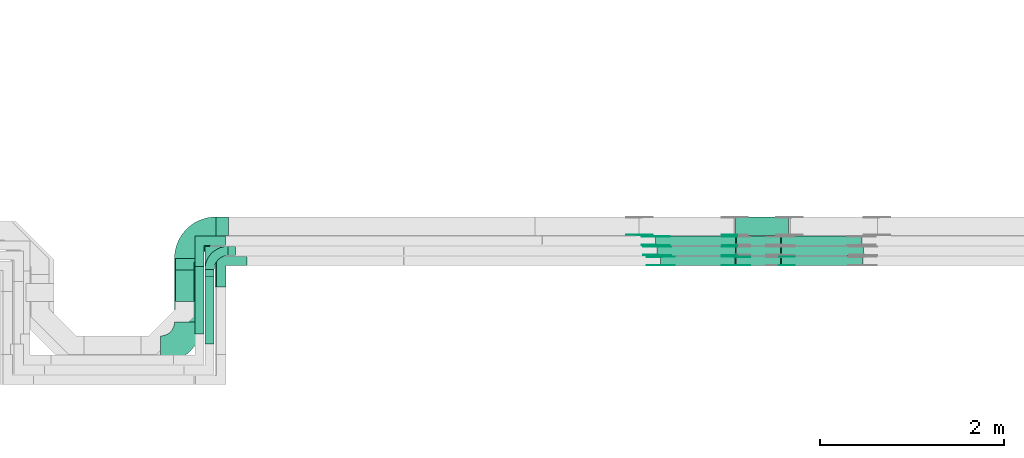
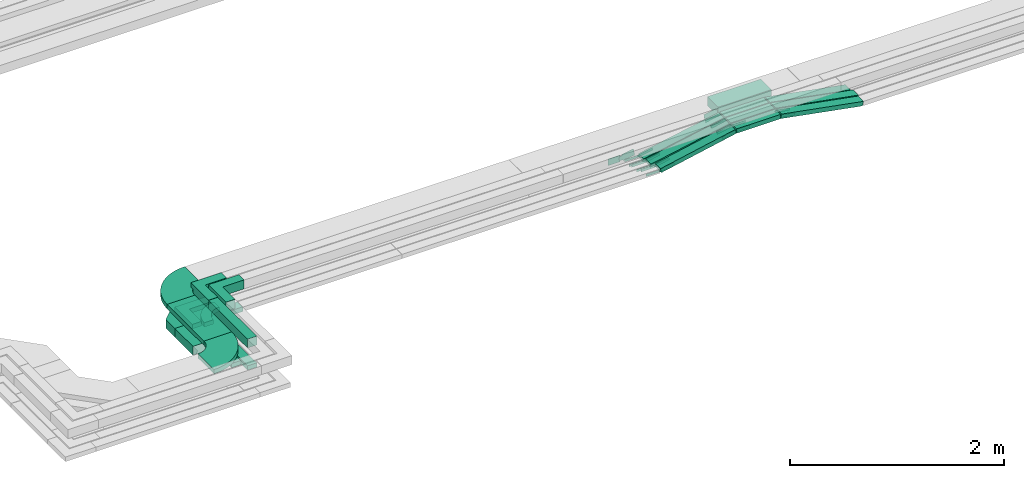
# One storey, part 20 of 32: 33 flow fittings, 15 flow segments.
"""IFC2X3 building model written with IfcOpenShell, lengths in millimetres."""

from ifc_helpers import new_model, entity, si_unit, converted_unit, derived_unit, direction, frame, frame_2d, origin, origin_2d_with_axis, place, context, subcontext, project, spatial, polyline, circle_curve, parameter, trimmed, segment, composite_curve, rectangle, outline, extrude, source, transform, mapped, material, type_object, type_shapes, element, save


model = new_model("IFC2X3")

# Units and contexts
model_context = context("Model", 3, precision=0.01, world=origin(), true_north=direction((6.12303176911189e-17, 1.0)))
body_context = subcontext(model_context, "Body", "Model", "MODEL_VIEW")
ifc_project = project(units=[si_unit("LENGTHUNIT", "METRE", prefix="MILLI"), si_unit("AREAUNIT", "SQUARE_METRE"), si_unit("VOLUMEUNIT", "CUBIC_METRE"), converted_unit("PLANEANGLEUNIT", "DEGREE", entity("IfcRatioMeasure", 0.0174532925199433), si_unit("PLANEANGLEUNIT", "RADIAN"), dimensions=[0, 0, 0, 0, 0, 0, 0]), si_unit("MASSUNIT", "GRAM", prefix="KILO"), derived_unit("MASSDENSITYUNIT", [(si_unit("MASSUNIT", "GRAM", prefix="KILO"), 1), (si_unit("LENGTHUNIT", "METRE"), -3)]), derived_unit("MOMENTOFINERTIAUNIT", [(si_unit("LENGTHUNIT", "METRE"), 4)]), si_unit("TIMEUNIT", "SECOND"), si_unit("FREQUENCYUNIT", "HERTZ"), si_unit("THERMODYNAMICTEMPERATUREUNIT", "DEGREE_CELSIUS"), derived_unit("THERMALTRANSMITTANCEUNIT", [(si_unit("MASSUNIT", "GRAM", prefix="KILO"), 1), (si_unit("THERMODYNAMICTEMPERATUREUNIT", "KELVIN"), -1), (si_unit("TIMEUNIT", "SECOND"), -3)]), derived_unit("VOLUMETRICFLOWRATEUNIT", [(si_unit("LENGTHUNIT", "METRE"), 3), (si_unit("TIMEUNIT", "SECOND"), -1)]), derived_unit("MASSFLOWRATEUNIT", [(si_unit("MASSUNIT", "GRAM", prefix="KILO"), 1), (si_unit("TIMEUNIT", "SECOND"), -1)]), derived_unit("ROTATIONALFREQUENCYUNIT", [(si_unit("TIMEUNIT", "SECOND"), -1)]), si_unit("ELECTRICCURRENTUNIT", "AMPERE"), si_unit("ELECTRICVOLTAGEUNIT", "VOLT"), si_unit("POWERUNIT", "WATT"), si_unit("FORCEUNIT", "NEWTON", prefix="KILO"), si_unit("ILLUMINANCEUNIT", "LUX"), si_unit("LUMINOUSFLUXUNIT", "LUMEN"), si_unit("LUMINOUSINTENSITYUNIT", "CANDELA"), derived_unit("USERDEFINED", [(si_unit("MASSUNIT", "GRAM", prefix="KILO"), -1), (si_unit("LENGTHUNIT", "METRE"), -2), (si_unit("TIMEUNIT", "SECOND"), 3), (si_unit("LUMINOUSFLUXUNIT", "LUMEN"), 1)]), derived_unit("LINEARVELOCITYUNIT", [(si_unit("LENGTHUNIT", "METRE"), 1), (si_unit("TIMEUNIT", "SECOND"), -1)]), si_unit("PRESSUREUNIT", "PASCAL"), derived_unit("USERDEFINED", [(si_unit("LENGTHUNIT", "METRE"), -2), (si_unit("MASSUNIT", "GRAM", prefix="KILO"), 1), (si_unit("TIMEUNIT", "SECOND"), -2)]), derived_unit("LINEARFORCEUNIT", [(si_unit("MASSUNIT", "GRAM", prefix="KILO"), 1), (si_unit("LENGTHUNIT", "METRE"), 1), (si_unit("TIMEUNIT", "SECOND"), -2), (si_unit("LENGTHUNIT", "METRE"), -1)]), derived_unit("PLANARFORCEUNIT", [(si_unit("MASSUNIT", "GRAM", prefix="KILO"), 1), (si_unit("LENGTHUNIT", "METRE"), 1), (si_unit("TIMEUNIT", "SECOND"), -2), (si_unit("LENGTHUNIT", "METRE"), -2)])], contexts=[model_context])

# Site, building, storey
site_placement = place(None, origin())
site = spatial("IfcSite", under=ifc_project, at=site_placement, CompositionType="ELEMENT")
building_placement = place(site_placement, origin())
building = spatial("IfcBuilding", under=site, at=building_placement, CompositionType="ELEMENT")
storey_placement = place(building_placement, frame((0.0, 0.0, 8100.0)))
storey = spatial("IfcBuildingStorey", under=building, at=storey_placement, CompositionType="ELEMENT", Elevation=8100.0)

# Flow segments
cable_carrier_segment_type = type_object("IfcCableCarrierSegmentType", PredefinedType="CABLETRAYSEGMENT")
flow_segment_1_placement = place(storey_placement, frame((44557.72, 9083.69, 2800.02)))
element("IfcFlowSegment", 1, at=flow_segment_1_placement, inside=storey, type_object=cable_carrier_segment_type, context=body_context, shape_type="SweptSolid", body=[
    extrude(rectangle(XDim=690.309773162948, YDim=300.000000000001, at=origin_2d_with_axis()), frame((150.0, 345.15, 0.0), z_axis=(0.0, 0.0, 1.0), x_axis=(0.0, -1.0, 0.0)), (0.0, 0.0, 1.0), 50.0000000000016),
])
flow_segment_2_placement = place(storey_placement, frame((44889.39, 8842.69, 2800.01)))
element("IfcFlowSegment", 2, at=flow_segment_2_placement, inside=storey, type_object=cable_carrier_segment_type, context=body_context, shape_type="SweptSolid", body=[
    extrude(rectangle(XDim=732.309773162997, YDim=99.9999999999946, at=origin_2d_with_axis()), frame((50.0, 366.15, 0.0), z_axis=(0.0, 0.0, 1.0), x_axis=(0.0, -1.0, 0.0)), (0.0, 0.0, 1.0), 99.9999999999968),
])
flow_segment_3_placement = place(storey_placement, frame((44569.39, 9308.69, 2547.39)))
element("IfcFlowSegment", 3, at=flow_segment_3_placement, inside=storey, type_object=cable_carrier_segment_type, context=body_context, shape_type="SweptSolid", body=[
    extrude(rectangle(XDim=340.309773162912, YDim=200.000000000007, at=origin_2d_with_axis()), frame((100.0, 170.15, 0.0), z_axis=(0.0, 0.0, 1.0), x_axis=(0.0, 1.0, 0.0)), (0.0, 0.0, 1.0), 99.9999999999989),
])
flow_segment_4_placement = place(storey_placement, frame((44779.39, 8952.69, 2544.93)))
element("IfcFlowSegment", 4, at=flow_segment_4_placement, inside=storey, type_object=cable_carrier_segment_type, context=body_context, shape_type="SweptSolid", body=[
    extrude(rectangle(XDim=732.309773162961, YDim=99.9999999999946, at=origin_2d_with_axis()), frame((50.0, 366.15, 0.0), z_axis=(0.0, 0.0, 1.0), x_axis=(0.0, 1.0, 0.0)), (0.0, 0.0, 1.0), 50.0000000000016),
])
flow_segment_5_placement = place(storey_placement, frame((44889.39, 8842.69, 2546.32)))
element("IfcFlowSegment", 5, at=flow_segment_5_placement, inside=storey, type_object=cable_carrier_segment_type, context=body_context, shape_type="SweptSolid", body=[
    extrude(rectangle(XDim=811.309773162958, YDim=99.9999999999946, at=origin_2d_with_axis()), frame((50.0, 405.65, 0.0), z_axis=(0.0, 0.0, 1.0), x_axis=(0.0, 1.0, 0.0)), (0.0, 0.0, 1.0), 50.0000000000016),
])
flow_segment_6_placement = place(storey_placement, frame((50660.64, 9695.0, 2713.3)))
element("IfcFlowSegment", 6, at=flow_segment_6_placement, inside=storey, type_object=cable_carrier_segment_type, context=body_context, shape_type="SweptSolid", body=[
    extrude(rectangle(XDim=477.273522129145, YDim=100.000000000001, at=origin_2d_with_axis()), frame((238.64, 50.0, 0.0)), (0.0, 0.0, 1.0), 50.0000000000017),
])
flow_segment_7_placement = place(storey_placement, frame((50650.96, 10025.0, 2713.61)))
element("IfcFlowSegment", 7, at=flow_segment_7_placement, inside=storey, type_object=cable_carrier_segment_type, context=body_context, shape_type="SweptSolid", body=[
    extrude(rectangle(XDim=577.431980396776, YDim=199.999999999998, at=origin_2d_with_axis()), frame((288.72, 100.0, 0.0)), (0.0, 0.0, 1.0), 99.9999999999989),
])
flow_segment_8_placement = place(storey_placement, frame((50662.44, 9915.0, 2713.31)))
element("IfcFlowSegment", 8, at=flow_segment_8_placement, inside=storey, type_object=cable_carrier_segment_type, context=body_context, shape_type="SweptSolid", body=[
    extrude(rectangle(XDim=475.291800517506, YDim=99.9999999999989, at=origin_2d_with_axis()), frame((237.65, 50.0, 0.0)), (0.0, 0.0, 1.0), 50.0000000000016),
])
flow_segment_9_placement = place(storey_placement, frame((50661.26, 9805.0, 2713.54)))
element("IfcFlowSegment", 9, at=flow_segment_9_placement, inside=storey, type_object=cable_carrier_segment_type, context=body_context, shape_type="SweptSolid", body=[
    extrude(rectangle(XDim=476.37052042903, YDim=99.9999999999989, at=origin_2d_with_axis()), frame((238.19, 50.0, 0.0), z_axis=(0.0, 0.0, 1.0), x_axis=(-1.0, 0.0, 0.0)), (0.0, 0.0, 1.0), 50.0000000000016),
])
flow_segment_10_placement = place(storey_placement, frame((49839.4, 9695.0, 2547.96)))
element("IfcFlowSegment", 10, at=flow_segment_10_placement, inside=storey, type_object=cable_carrier_segment_type, context=body_context, shape_type="SweptSolid", body=[
    extrude(rectangle(XDim=50.0000000000023, YDim=100.000000000001, at=origin_2d_with_axis()), frame((5.0, 50.0, 24.5), z_axis=(0.979786827050049, 0.0, 0.200044428913172), x_axis=(-0.200044428890075, 1.51960900459464e-05, 0.979786826936922)), (0.0, 0.0, 1.0), 825.136376037674),
])
flow_segment_11_placement = place(storey_placement, frame((51140.63, 9695.0, 2549.42)))
element("IfcFlowSegment", 11, at=flow_segment_11_placement, inside=storey, type_object=cable_carrier_segment_type, context=body_context, shape_type="SweptSolid", body=[
    extrude(rectangle(XDim=50.0000000000012, YDim=100.000000000001, at=origin_2d_with_axis()), frame((4.56, 50.0, 188.22), z_axis=(0.983194962125325, 0.0, -0.182558665780022), x_axis=(0.182558665780022, 0.0, 0.983194962125325)), (0.0, 0.0, 1.0), 896.373011194787),
])
flow_segment_12_placement = place(storey_placement, frame((49799.87, 9805.0, 2547.51)))
element("IfcFlowSegment", 12, at=flow_segment_12_placement, inside=storey, type_object=cable_carrier_segment_type, context=body_context, shape_type="SweptSolid", body=[
    extrude(rectangle(XDim=49.9999999999987, YDim=99.9999999999989, at=origin_2d_with_axis()), frame((4.79, 50.0, 24.54), z_axis=(0.981470478195865, 0.0, 0.191613414013684), x_axis=(-0.191613414013684, 0.0, 0.981470478195865)), (0.0, 0.0, 1.0), 865.091688195415),
])
flow_segment_13_placement = place(storey_placement, frame((51140.33, 9805.0, 2551.09)))
element("IfcFlowSegment", 13, at=flow_segment_13_placement, inside=storey, type_object=cable_carrier_segment_type, context=body_context, shape_type="SweptSolid", body=[
    extrude(rectangle(XDim=50.0000000000008, YDim=99.9999999999989, at=frame_2d((0.0, 0.0), x_axis=(0.0, 1.0))), frame((4.47, 50.0, 186.81), z_axis=(0.983855320382255, 0.0, -0.178965663062864), x_axis=(0.0, 1.0, 0.0)), (0.0, 0.0, 1.0), 906.383158684558),
])
flow_segment_14_placement = place(storey_placement, frame((49784.86, 9915.0, 2546.09)))
element("IfcFlowSegment", 14, at=flow_segment_14_placement, inside=storey, type_object=cable_carrier_segment_type, context=body_context, shape_type="SweptSolid", body=[
    extrude(rectangle(XDim=50.0000000000003, YDim=99.9999999999989, at=origin_2d_with_axis()), frame((4.74, 50.0, 24.55), z_axis=(0.981892404551273, 0.0, 0.189439451763671), x_axis=(-0.189439451763671, 0.0, 0.981892404551273)), (0.0, 0.0, 1.0), 881.321250243893),
])
flow_segment_15_placement = place(storey_placement, frame((51140.45, 9915.0, 2550.97)))
element("IfcFlowSegment", 15, at=flow_segment_15_placement, inside=storey, type_object=cable_carrier_segment_type, context=body_context, shape_type="SweptSolid", body=[
    extrude(rectangle(XDim=50.0000000000006, YDim=99.9999999999989, at=frame_2d((0.0, 0.0), x_axis=(0.0, 1.0))), frame((4.57, 50.0, 186.67), z_axis=(0.983116338122434, 0.0, -0.182981599393862), x_axis=(0.0, 1.0, 0.0)), (0.0, 0.0, 1.0), 885.843681158498),
])

# Flow fittings
ifc_material_1 = material()
cable_carrier_fitting_type_1 = type_object("IfcCableCarrierFittingType", Name="470_DKC_G5_Sheet horizontal bend:-", PredefinedType="NOTDEFINED", material=ifc_material_1)
shared_shape_1 = source(origin(), body_context, "Body", "SweptSolid", [
    extrude(outline(polyline([(-269.5, -306.5), (-102.08, -306.5), (306.5, 102.08), (306.5, 269.5), (106.5, 269.5), (106.5, 184.92), (-184.92, -106.5), (-269.5, -106.5), (-269.5, -306.5)])), frame((-206.5, 206.5, -50.0)), (0.0, 0.0, 1.0), 100.0),
])
type_shapes(cable_carrier_fitting_type_1, [shared_shape_1])
flow_fitting_1_placement = place(storey_placement, frame((44669.39, 10125.0, 2597.39), z_axis=(0.0, 0.0, 1.0), x_axis=(-1.0, 0.0, 0.0)))
element("IfcFlowFitting", 16, at=flow_fitting_1_placement, inside=storey, type_object=cable_carrier_fitting_type_1, material=ifc_material_1, Name="470_DKC_G5_Sheet horizontal bend:-", ObjectType="470_DKC_G5_Sheet horizontal bend:-", context=body_context, shape_type="MappedRepresentation", body=[
    mapped(shared_shape_1, transform((0.0, 0.0, 0.0), scale=1.0)),
])
cable_carrier_fitting_type_2 = type_object("IfcCableCarrierFittingType", Name="470_DKC_F5_Mesh horizontal angle:At right angles", PredefinedType="NOTDEFINED", material=ifc_material_1)
shared_shape_2 = source(origin(), body_context, "Body", "SweptSolid", [
    extrude(outline(polyline([(-143.33, -143.33), (186.67, -143.33), (186.67, -43.33), (-43.33, -43.33), (-43.33, 186.67), (-143.33, 186.67), (-143.33, -143.33)])), frame((-93.33, 93.33, -25.0), z_axis=(0.0, 0.0, 1.0), x_axis=(0.0, 1.0, 0.0)), (0.0, 0.0, 1.0), 51.9999999999999),
])
type_shapes(cable_carrier_fitting_type_2, [shared_shape_2])
for number, where, z_axis, x_axis, name in (
    (17, (44829.39, 9965.0, 2569.93), (0.0, 0.0, 1.0), (-1.0, 0.0, 0.0), "470_DKC_F5_Mesh horizontal angle:At right angles"),
    (18, (45049.9, 9745.0, 2571.67), (0.0, 0.0, 1.0), (-1.0, 0.0, 0.0), "470_DKC_F5_Mesh horizontal angle:At right angles"),
):
    element("IfcFlowFitting", number, at=place(storey_placement, frame(where, z_axis=z_axis, x_axis=x_axis)), inside=storey, type_object=cable_carrier_fitting_type_2, material=ifc_material_1, Name=name, ObjectType="470_DKC_F5_Mesh horizontal angle:At right angles", context=body_context, shape_type="MappedRepresentation", body=[
        mapped(shared_shape_2, transform((0.0, 0.0, 0.0), scale=1.0)),
    ])
cable_carrier_fitting_type_3 = type_object("IfcCableCarrierFittingType", Name="470_DKC_F5_Mesh horizontal angle:At right angles", PredefinedType="NOTDEFINED", material=ifc_material_1)
shared_shape_3 = source(origin(), body_context, "Body", "SweptSolid", [
    extrude(outline(polyline([(-143.33, -143.33), (186.67, -143.33), (186.67, -43.33), (-43.33, -43.33), (-43.33, 186.67), (-143.33, 186.67), (-143.33, -143.33)])), frame((-93.33, 93.33, -50.0), z_axis=(0.0, 0.0, 1.0), x_axis=(0.0, 1.0, 0.0)), (0.0, 0.0, 1.0), 102.0),
])
type_shapes(cable_carrier_fitting_type_3, [shared_shape_3])
for number, where, z_axis, x_axis, name in (
    (19, (44939.39, 9855.0, 2850.01), (2.17578588737003e-05, 0.0, 1.0), (-1.0, 0.0, 2.17578588737003e-05), "470_DKC_F5_Mesh horizontal angle:At right angles"),
    (20, (45064.9, 9745.0, 2849.28), (4.69987070140133e-07, 0.0, 1.0), (-1.0, 0.0, 4.69987070140133e-07), "470_DKC_F5_Mesh horizontal angle:At right angles"),
):
    element("IfcFlowFitting", number, at=place(storey_placement, frame(where, z_axis=z_axis, x_axis=x_axis)), inside=storey, type_object=cable_carrier_fitting_type_3, material=ifc_material_1, Name=name, ObjectType="470_DKC_F5_Mesh horizontal angle:At right angles", context=body_context, shape_type="MappedRepresentation", body=[
        mapped(shared_shape_3, transform((0.0, 0.0, 0.0), scale=1.0)),
    ])
cable_carrier_fitting_type_4 = type_object("IfcCableCarrierFittingType", Name="470_DKC_S5_Variable Angle Elbow 0-45:-", PredefinedType="NOTDEFINED", material=ifc_material_1)
shared_shape_4 = source(origin(), body_context, "Body", "SweptSolid", [
    extrude(outline(composite_curve([segment(polyline([(-150.75, -300.25), (-149.75, -300.25)]), True, "CONTINUOUS"), segment(trimmed(circle_curve(frame_2d((-149.75, 149.75), x_axis=(0.0, -1.0)), 450.0), [parameter(0.0)], [parameter(90.0000000000001)], True, "PARAMETER"), True, "CONTINUOUS"), segment(polyline([(300.25, 149.75), (300.25, 150.75)]), True, "CONTINUOUS"), segment(polyline([(300.25, 150.75), (0.25, 150.75)]), True, "CONTINUOUS"), segment(polyline([(0.25, 150.75), (0.25, 149.75)]), True, "CONTINUOUS"), segment(trimmed(circle_curve(frame_2d((-149.75, 149.75), x_axis=(0.0, -1.0)), 150.0), [parameter(0.0)], [parameter(90.0000000000001)], True, "PARAMETER"), False, "CONTINUOUS"), segment(polyline([(-149.75, -0.25), (-150.75, -0.25)]), True, "CONTINUOUS"), segment(polyline([(-150.75, -0.25), (-150.75, -300.25)]), True, "CONTINUOUS")], self_intersect=False)), frame((-150.25, 150.25, -25.0)), (0.0, 0.0, 1.0), 49.9999999999974),
])
type_shapes(cable_carrier_fitting_type_4, [shared_shape_4])
flow_fitting_2_placement = place(storey_placement, frame((44707.72, 8782.69, 2825.02)))
element("IfcFlowFitting", 21, at=flow_fitting_2_placement, inside=storey, type_object=cable_carrier_fitting_type_4, material=ifc_material_1, Name="470_DKC_S5_Variable Angle Elbow 0-45:-", ObjectType="470_DKC_S5_Variable Angle Elbow 0-45:-", context=body_context, shape_type="MappedRepresentation", body=[
    mapped(shared_shape_4, transform((0.0, 0.0, 0.0), scale=1.0)),
])
flow_fitting_3_placement = place(storey_placement, frame((44707.72, 10075.0, 2825.02), z_axis=(0.00105535618082575, 0.0, 0.999999443111511), x_axis=(-0.999999443111511, 0.0, 0.00105535618082575)))
element("IfcFlowFitting", 22, at=flow_fitting_3_placement, inside=storey, type_object=cable_carrier_fitting_type_4, material=ifc_material_1, Name="470_DKC_S5_Variable Angle Elbow 0-45:-", ObjectType="470_DKC_S5_Variable Angle Elbow 0-45:-", context=body_context, shape_type="MappedRepresentation", body=[
    mapped(shared_shape_4, transform((0.0, 0.0, 0.0), scale=1.0)),
])
cable_carrier_fitting_type_5 = type_object("IfcCableCarrierFittingType", Name="470_DKC_S5_Variable Angle Elbow 0-45:-", PredefinedType="NOTDEFINED", material=ifc_material_1)
shared_shape_5 = source(origin(), body_context, "Body", "SweptSolid", [
    extrude(outline(composite_curve([segment(polyline([(-100.75, -150.25), (-99.75, -150.25)]), True, "CONTINUOUS"), segment(trimmed(circle_curve(frame_2d((-99.75, 99.75), x_axis=(0.0, -1.0)), 250.0), [parameter(0.0)], [parameter(90.0000000000001)], True, "PARAMETER"), True, "CONTINUOUS"), segment(polyline([(150.25, 99.75), (150.25, 100.75)]), True, "CONTINUOUS"), segment(polyline([(150.25, 100.75), (50.25, 100.75)]), True, "CONTINUOUS"), segment(polyline([(50.25, 100.75), (50.25, 99.75)]), True, "CONTINUOUS"), segment(trimmed(circle_curve(frame_2d((-99.75, 99.75), x_axis=(0.0, -1.0)), 150.0), [parameter(0.0)], [parameter(90.0000000000001)], True, "PARAMETER"), False, "CONTINUOUS"), segment(polyline([(-99.75, -50.25), (-100.75, -50.25)]), True, "CONTINUOUS"), segment(polyline([(-100.75, -50.25), (-100.75, -150.25)]), True, "CONTINUOUS")], self_intersect=False)), frame((-100.25, 100.25, -25.0)), (0.0, 0.0, 1.0), 49.9999999999997),
])
type_shapes(cable_carrier_fitting_type_5, [shared_shape_5])
flow_fitting_4_placement = place(storey_placement, frame((44939.39, 9855.0, 2571.32), z_axis=(0.0, 0.0, 1.0), x_axis=(-1.0, 0.0, 0.0)))
element("IfcFlowFitting", 23, at=flow_fitting_4_placement, inside=storey, type_object=cable_carrier_fitting_type_5, material=ifc_material_1, Name="470_DKC_S5_Variable Angle Elbow 0-45:-", ObjectType="470_DKC_S5_Variable Angle Elbow 0-45:-", context=body_context, shape_type="MappedRepresentation", body=[
    mapped(shared_shape_5, transform((0.0, 0.0, 0.0), scale=1.0)),
])
ifc_material_2 = material(Name="G")
cable_carrier_fitting_type_6 = type_object("IfcCableCarrierFittingType", PredefinedType="NOTDEFINED", material=ifc_material_2)
shared_shape_6 = source(origin(), body_context, "Body", "SweptSolid", [
    extrude(outline(composite_curve([segment(trimmed(circle_curve(frame_2d((-44.59, 0.0), x_axis=(1.0, 0.0)), 12.5), [parameter(90.0000000000007)], [parameter(270.0)], True, "PARAMETER"), True, "CONTINUOUS"), segment(polyline([(-44.59, -12.5), (-33.09, -12.5)]), True, "CONTINUOUS"), segment(polyline([(-33.09, -12.5), (-31.23, -14.5)]), True, "CONTINUOUS"), segment(polyline([(-31.23, -14.5), (108.91, -14.5)]), True, "CONTINUOUS"), segment(polyline([(108.91, -14.5), (108.91, 14.5)]), True, "CONTINUOUS"), segment(polyline([(108.91, 14.5), (-31.23, 14.5)]), True, "CONTINUOUS"), segment(polyline([(-31.23, 14.5), (-33.09, 12.5)]), True, "CONTINUOUS"), segment(polyline([(-33.09, 12.5), (-44.59, 12.5)]), True, "CONTINUOUS")], self_intersect=False)), frame((44.59, 0.0, 0.0), z_axis=(0.0, 0.0, -1.0), x_axis=(1.0, 0.0, 0.0)), (0.0, 0.0, -1.0), 2.0),
])
type_shapes(cable_carrier_fitting_type_6, [shared_shape_6])
flow_fitting_5_placement = place(storey_placement, frame((49840.55, 9699.54, 2571.67), z_axis=(0.0, -1.0, 0.0), x_axis=(0.979786827050029, 0.0, 0.200044428913269)))
element("IfcFlowFitting", 24, at=flow_fitting_5_placement, inside=storey, type_object=cable_carrier_fitting_type_6, material=ifc_material_2, context=body_context, shape_type="MappedRepresentation", body=[
    mapped(shared_shape_6, transform((0.0, 0.0, 0.0), scale=1.0)),
])
cable_carrier_fitting_type_7 = type_object("IfcCableCarrierFittingType", PredefinedType="NOTDEFINED", material=ifc_material_2)
type_shapes(cable_carrier_fitting_type_7, [shared_shape_6])
flow_fitting_6_placement = place(storey_placement, frame((49840.55, 9788.46, 2571.67), z_axis=(0.0, 1.0, 0.0), x_axis=(-1.0, 0.0, 0.0)))
element("IfcFlowFitting", 25, at=flow_fitting_6_placement, inside=storey, type_object=cable_carrier_fitting_type_7, material=ifc_material_2, context=body_context, shape_type="MappedRepresentation", body=[
    mapped(shared_shape_6, transform((0.0, 0.0, 0.0), scale=1.0)),
])
flow_fitting_7_placement = place(storey_placement, frame((50656.71, 9699.54, 2738.31), z_axis=(-3.03989314942444e-06, -1.0, 1.48889288550001e-05), x_axis=(-0.979786827054556, 0.0, -0.200044428891096)))
element("IfcFlowFitting", 26, at=flow_fitting_7_placement, inside=storey, type_object=cable_carrier_fitting_type_6, material=ifc_material_2, context=body_context, shape_type="MappedRepresentation", body=[
    mapped(shared_shape_6, transform((0.0, 0.0, 0.0), scale=1.0)),
])
flow_fitting_8_placement = place(storey_placement, frame((50656.71, 9788.46, 2738.31), z_axis=(3.03989316299203e-06, 1.0, -1.48889288550001e-05), x_axis=(1.0, -3.03989316332888e-06, 0.0)))
element("IfcFlowFitting", 27, at=flow_fitting_8_placement, inside=storey, type_object=cable_carrier_fitting_type_7, material=ifc_material_2, context=body_context, shape_type="MappedRepresentation", body=[
    mapped(shared_shape_6, transform((0.0, 0.0, 0.0), scale=1.0)),
])
for number, where, z_axis, x_axis in (
    (28, (51141.58, 9790.46, 2738.31), (3.03989318177189e-06, 1.0, 1.63717654735008e-05), (0.983194962125356, 0.0, -0.182558665779853)),
    (29, (50657.45, 9809.54, 2738.54), (0.0, -1.0, 0.0), (-0.981470478195842, 0.0, -0.191613414013801)),
    (30, (49800.92, 9809.54, 2571.32), (0.0, -1.0, 0.0), (0.981470478195842, 0.0, 0.191613414013801)),
):
    element("IfcFlowFitting", number, at=place(storey_placement, frame(where, z_axis=z_axis, x_axis=x_axis)), inside=storey, type_object=cable_carrier_fitting_type_6, material=ifc_material_2, context=body_context, shape_type="MappedRepresentation", body=[
        mapped(shared_shape_6, transform((0.0, 0.0, 0.0), scale=1.0)),
    ])
flow_fitting_9_placement = place(storey_placement, frame((49800.92, 9898.46, 2571.32), z_axis=(0.0, 1.0, 0.0), x_axis=(-1.0, 0.0, 0.0)))
element("IfcFlowFitting", 31, at=flow_fitting_9_placement, inside=storey, type_object=cable_carrier_fitting_type_7, material=ifc_material_2, context=body_context, shape_type="MappedRepresentation", body=[
    mapped(shared_shape_6, transform((0.0, 0.0, 0.0), scale=1.0)),
])
for number, where, z_axis, x_axis in (
    (32, (50658.67, 9919.54, 2738.31), (0.0, -1.0, 0.0), (-0.9818924045513, 0.0, -0.189439451763528)),
    (33, (49785.9, 9919.54, 2569.93), (0.0, -1.0, 0.0), (0.9818924045513, 0.0, 0.189439451763528)),
):
    element("IfcFlowFitting", number, at=place(storey_placement, frame(where, z_axis=z_axis, x_axis=x_axis)), inside=storey, type_object=cable_carrier_fitting_type_6, material=ifc_material_2, context=body_context, shape_type="MappedRepresentation", body=[
        mapped(shared_shape_6, transform((0.0, 0.0, 0.0), scale=1.0)),
    ])
flow_fitting_10_placement = place(storey_placement, frame((49785.9, 10008.46, 2569.93), z_axis=(0.0, 1.0, 0.0), x_axis=(-1.0, 0.0, 0.0)))
element("IfcFlowFitting", 34, at=flow_fitting_10_placement, inside=storey, type_object=cable_carrier_fitting_type_7, material=ifc_material_2, context=body_context, shape_type="MappedRepresentation", body=[
    mapped(shared_shape_6, transform((0.0, 0.0, 0.0), scale=1.0)),
])
cable_carrier_fitting_type_8 = type_object("IfcCableCarrierFittingType", PredefinedType="NOTDEFINED", material=ifc_material_2)
shared_shape_7 = source(origin(), body_context, "Body", "SweptSolid", [
    extrude(outline(composite_curve([segment(trimmed(circle_curve(frame_2d((-44.59, 0.0), x_axis=(1.0, 0.0)), 12.5), [parameter(90.0000000000007)], [parameter(270.0)], True, "PARAMETER"), True, "CONTINUOUS"), segment(polyline([(-44.59, -12.5), (-33.09, -12.5)]), True, "CONTINUOUS"), segment(polyline([(-33.09, -12.5), (-31.23, -14.5)]), True, "CONTINUOUS"), segment(polyline([(-31.23, -14.5), (108.91, -14.5)]), True, "CONTINUOUS"), segment(polyline([(108.91, -14.5), (108.91, 14.5)]), True, "CONTINUOUS"), segment(polyline([(108.91, 14.5), (-31.23, 14.5)]), True, "CONTINUOUS"), segment(polyline([(-31.23, 14.5), (-33.09, 12.5)]), True, "CONTINUOUS"), segment(polyline([(-33.09, 12.5), (-44.59, 12.5)]), True, "CONTINUOUS")], self_intersect=False)), frame((44.59, 0.0, 0.0)), (0.0, 0.0, 1.0), 2.0),
])
type_shapes(cable_carrier_fitting_type_8, [shared_shape_7])
flow_fitting_11_placement = place(storey_placement, frame((49840.55, 9790.46, 2571.67), z_axis=(0.0, 1.0, 0.0), x_axis=(0.979786827050029, 0.0, 0.200044428913269)))
element("IfcFlowFitting", 35, at=flow_fitting_11_placement, inside=storey, type_object=cable_carrier_fitting_type_8, material=ifc_material_2, context=body_context, shape_type="MappedRepresentation", body=[
    mapped(shared_shape_7, transform((0.0, 0.0, 0.0), scale=1.0)),
])
cable_carrier_fitting_type_9 = type_object("IfcCableCarrierFittingType", PredefinedType="NOTDEFINED", material=ifc_material_2)
type_shapes(cable_carrier_fitting_type_9, [shared_shape_7])
flow_fitting_12_placement = place(storey_placement, frame((49840.55, 9701.54, 2571.67), z_axis=(0.0, -1.0, 0.0), x_axis=(-1.0, 0.0, 0.0)))
element("IfcFlowFitting", 36, at=flow_fitting_12_placement, inside=storey, type_object=cable_carrier_fitting_type_9, material=ifc_material_2, context=body_context, shape_type="MappedRepresentation", body=[
    mapped(shared_shape_7, transform((0.0, 0.0, 0.0), scale=1.0)),
])
flow_fitting_13_placement = place(storey_placement, frame((50656.71, 9790.46, 2738.31), z_axis=(3.03989313613108e-06, 1.0, -1.48889288577142e-05), x_axis=(-0.979786827054556, 0.0, -0.200044428891096)))
element("IfcFlowFitting", 37, at=flow_fitting_13_placement, inside=storey, type_object=cable_carrier_fitting_type_8, material=ifc_material_2, context=body_context, shape_type="MappedRepresentation", body=[
    mapped(shared_shape_7, transform((0.0, 0.0, 0.0), scale=1.0)),
])
flow_fitting_14_placement = place(storey_placement, frame((50656.71, 9701.54, 2738.31), z_axis=(-3.03989313585684e-06, -1.0, 1.48889288685677e-05), x_axis=(1.0, -3.03989313619369e-06, 0.0)))
element("IfcFlowFitting", 38, at=flow_fitting_14_placement, inside=storey, type_object=cable_carrier_fitting_type_9, material=ifc_material_2, context=body_context, shape_type="MappedRepresentation", body=[
    mapped(shared_shape_7, transform((0.0, 0.0, 0.0), scale=1.0)),
])
for number, where, z_axis, x_axis in (
    (39, (51141.58, 9699.54, 2738.31), (-3.0398931684323e-06, -1.0, -1.63717654759777e-05), (0.983194962125356, 0.0, -0.182558665779853)),
    (40, (50657.45, 9900.46, 2738.54), (0.0, 1.0, 0.0), (-0.981470478195842, 0.0, -0.191613414013801)),
    (41, (49800.92, 9900.46, 2571.32), (0.0, 1.0, 0.0), (0.981470478195842, 0.0, 0.191613414013801)),
):
    element("IfcFlowFitting", number, at=place(storey_placement, frame(where, z_axis=z_axis, x_axis=x_axis)), inside=storey, type_object=cable_carrier_fitting_type_8, material=ifc_material_2, context=body_context, shape_type="MappedRepresentation", body=[
        mapped(shared_shape_7, transform((0.0, 0.0, 0.0), scale=1.0)),
    ])
flow_fitting_15_placement = place(storey_placement, frame((49800.92, 9811.54, 2571.32), z_axis=(0.0, -1.0, 0.0), x_axis=(-1.0, 0.0, 0.0)))
element("IfcFlowFitting", 42, at=flow_fitting_15_placement, inside=storey, type_object=cable_carrier_fitting_type_9, material=ifc_material_2, context=body_context, shape_type="MappedRepresentation", body=[
    mapped(shared_shape_7, transform((0.0, 0.0, 0.0), scale=1.0)),
])
for number, where, z_axis, x_axis in (
    (43, (50658.67, 10010.46, 2738.31), (0.0, 1.0, 0.0), (-0.9818924045513, 0.0, -0.189439451763528)),
    (44, (49785.9, 10010.46, 2569.93), (0.0, 1.0, 0.0), (0.9818924045513, 0.0, 0.189439451763528)),
):
    element("IfcFlowFitting", number, at=place(storey_placement, frame(where, z_axis=z_axis, x_axis=x_axis)), inside=storey, type_object=cable_carrier_fitting_type_8, material=ifc_material_2, context=body_context, shape_type="MappedRepresentation", body=[
        mapped(shared_shape_7, transform((0.0, 0.0, 0.0), scale=1.0)),
    ])
flow_fitting_16_placement = place(storey_placement, frame((49785.9, 9921.54, 2569.93), z_axis=(0.0, -1.0, 0.0), x_axis=(-1.0, 0.0, 0.0)))
element("IfcFlowFitting", 45, at=flow_fitting_16_placement, inside=storey, type_object=cable_carrier_fitting_type_9, material=ifc_material_2, context=body_context, shape_type="MappedRepresentation", body=[
    mapped(shared_shape_7, transform((0.0, 0.0, 0.0), scale=1.0)),
])
cable_carrier_fitting_type_10 = type_object("IfcCableCarrierFittingType", PredefinedType="NOTDEFINED", material=ifc_material_2)
shared_shape_8 = source(origin(), body_context, "Body", "SweptSolid", [
    extrude(outline(composite_curve([segment(trimmed(circle_curve(frame_2d((-41.47, 0.0), x_axis=(1.0, 0.0)), 25.0), [parameter(90.0000000000007)], [parameter(270.0)], True, "PARAMETER"), True, "CONTINUOUS"), segment(polyline([(-41.47, -25.0), (-29.97, -25.0)]), True, "CONTINUOUS"), segment(polyline([(-29.97, -25.0), (-28.1, -38.5)]), True, "CONTINUOUS"), segment(polyline([(-28.1, -38.5), (99.53, -38.5)]), True, "CONTINUOUS"), segment(polyline([(99.53, -38.5), (99.53, 38.5)]), True, "CONTINUOUS"), segment(polyline([(99.53, 38.5), (-28.1, 38.5)]), True, "CONTINUOUS"), segment(polyline([(-28.1, 38.5), (-29.97, 25.0)]), True, "CONTINUOUS"), segment(polyline([(-29.97, 25.0), (-41.47, 25.0)]), True, "CONTINUOUS")], self_intersect=False)), frame((41.47, 0.0, 0.0), z_axis=(0.0, 0.0, -1.0), x_axis=(1.0, 0.0, 0.0)), (0.0, 0.0, -1.0), 2.0),
])
type_shapes(cable_carrier_fitting_type_10, [shared_shape_8])
flow_fitting_17_placement = place(storey_placement, frame((49608.28, 10029.54, 2597.39), z_axis=(0.0, -1.0, 0.0), x_axis=(0.987405642693208, 0.0, 0.15820902874872)))
element("IfcFlowFitting", 46, at=flow_fitting_17_placement, inside=storey, type_object=cable_carrier_fitting_type_10, material=ifc_material_2, context=body_context, shape_type="MappedRepresentation", body=[
    mapped(shared_shape_8, transform((0.0, 0.0, 0.0), scale=1.0)),
])
cable_carrier_fitting_type_11 = type_object("IfcCableCarrierFittingType", PredefinedType="NOTDEFINED", material=ifc_material_2)
type_shapes(cable_carrier_fitting_type_11, [shared_shape_8])
flow_fitting_18_placement = place(storey_placement, frame((50645.66, 10031.54, 2763.61), z_axis=(0.0, -1.0, 0.0), x_axis=(-0.987405642693216, 0.0, -0.158209028748672)))
element("IfcFlowFitting", 47, at=flow_fitting_18_placement, inside=storey, type_object=cable_carrier_fitting_type_11, material=ifc_material_2, context=body_context, shape_type="MappedRepresentation", body=[
    mapped(shared_shape_8, transform((0.0, 0.0, 0.0), scale=1.0)),
])
cable_carrier_fitting_type_12 = type_object("IfcCableCarrierFittingType", PredefinedType="NOTDEFINED", material=ifc_material_2)
shared_shape_9 = source(origin(), body_context, "Body", "SweptSolid", [
    extrude(outline(composite_curve([segment(trimmed(circle_curve(frame_2d((-41.47, 0.0), x_axis=(1.0, 0.0)), 25.0), [parameter(90.0000000000007)], [parameter(270.0)], True, "PARAMETER"), True, "CONTINUOUS"), segment(polyline([(-41.47, -25.0), (-29.97, -25.0)]), True, "CONTINUOUS"), segment(polyline([(-29.97, -25.0), (-28.1, -38.5)]), True, "CONTINUOUS"), segment(polyline([(-28.1, -38.5), (99.53, -38.5)]), True, "CONTINUOUS"), segment(polyline([(99.53, -38.5), (99.53, 38.5)]), True, "CONTINUOUS"), segment(polyline([(99.53, 38.5), (-28.1, 38.5)]), True, "CONTINUOUS"), segment(polyline([(-28.1, 38.5), (-29.97, 25.0)]), True, "CONTINUOUS"), segment(polyline([(-29.97, 25.0), (-41.47, 25.0)]), True, "CONTINUOUS")], self_intersect=False)), frame((41.47, 0.0, 0.0)), (0.0, 0.0, 1.0), 2.0),
])
type_shapes(cable_carrier_fitting_type_12, [shared_shape_9])
flow_fitting_19_placement = place(storey_placement, frame((49608.28, 10031.54, 2597.39), z_axis=(0.0, -1.0, 0.0), x_axis=(-1.0, 0.0, 0.0)))
element("IfcFlowFitting", 48, at=flow_fitting_19_placement, inside=storey, type_object=cable_carrier_fitting_type_12, material=ifc_material_2, context=body_context, shape_type="MappedRepresentation", body=[
    mapped(shared_shape_9, transform((0.0, 0.0, 0.0), scale=1.0)),
])

save(model, "model.ifc")
